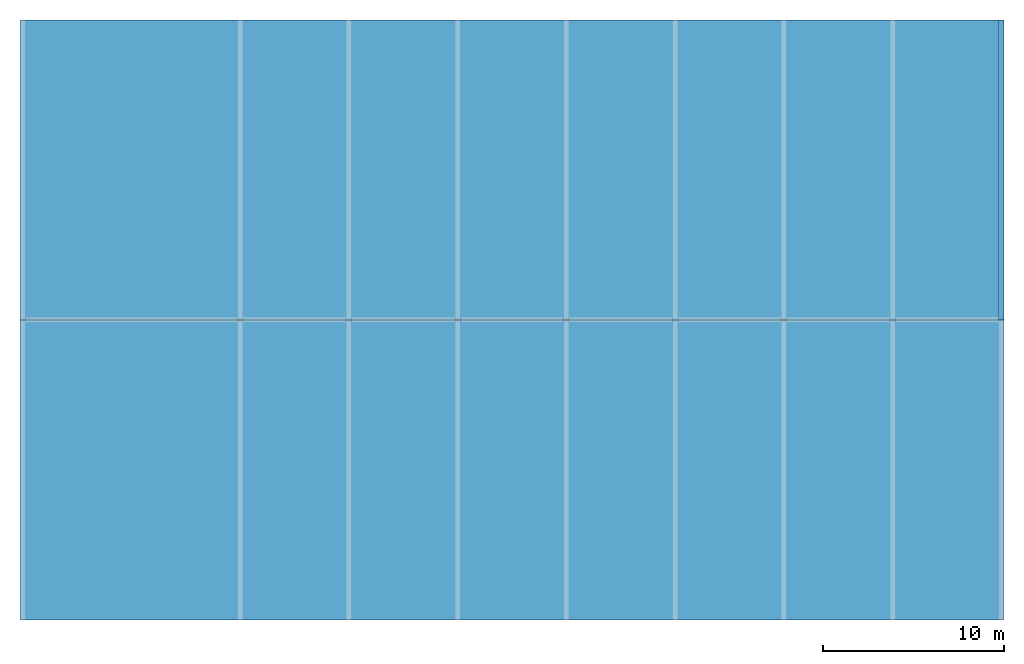
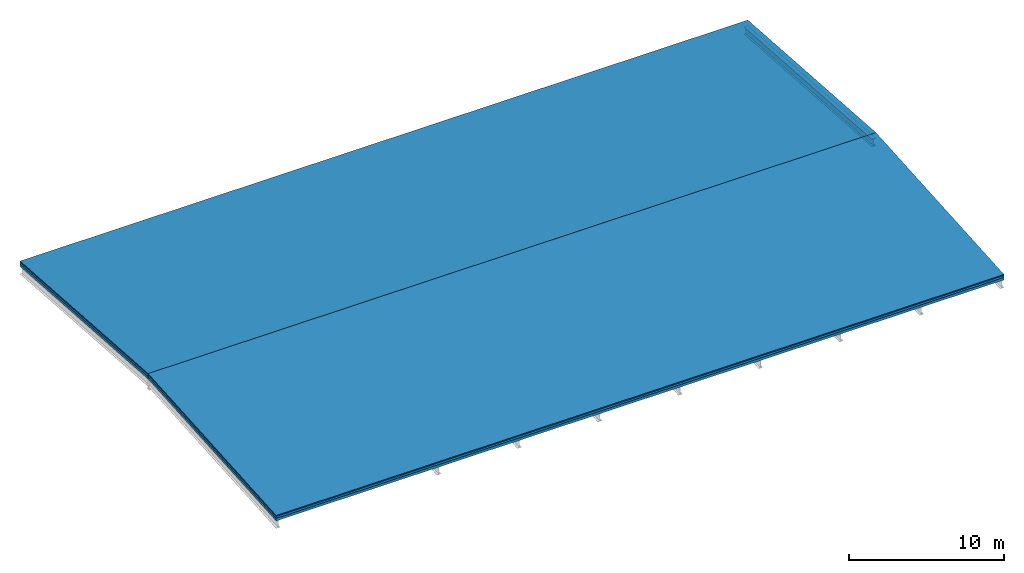
# One storey, part 3 of 3: 6 building element parts, 1 beam, 3 elements without a shape of their own.
"""IFC2X3 building model written with IfcOpenShell, lengths in millimetres."""

from ifc_helpers import new_model, entity, si_unit, converted_unit, frame, origin, origin_with_axes, place, context, subcontext, project, spatial, faceted_brep, material, element, aggregate, save


model = new_model("IFC2X3")

# Units and contexts
model_context = context("Model", 3, precision=1e-05, world=origin())
body_context = subcontext(model_context, "Body", "Model", "MODEL_VIEW")
ifc_project = project(units=[si_unit("LENGTHUNIT", "METRE", prefix="MILLI"), converted_unit("PLANEANGLEUNIT", "DEGREE", entity("IfcPlaneAngleMeasure", 0.0174532925199433), si_unit("PLANEANGLEUNIT", "RADIAN"), dimensions=[0, 0, 0, 0, 0, 0, 0]), si_unit("AREAUNIT", "SQUARE_METRE"), si_unit("VOLUMEUNIT", "CUBIC_METRE")], contexts=[model_context])

# Building, storey
building_placement = place(None, origin())
building = spatial("IfcBuilding", under=ifc_project, at=building_placement, CompositionType="ELEMENT")
storey_placement = place(building_placement, frame((0.0, 0.0, 7000.0), z_axis=(0.0, 0.0, 1.0), x_axis=(1.0, 0.0, 0.0)))
storey = spatial("IfcBuildingStorey", under=building, at=storey_placement, Name="Dach", CompositionType="ELEMENT", Elevation=7000.0)

# Beam
ifc_material_1 = material(Name="Stahl")
beam_placement = place(storey_placement, frame((53980.0, 33250.0, -17.48170298587866), z_axis=(0.0, 0.0, 1.0), x_axis=(-5.27561881390943e-15, -1.0, 0.0)))
element("IfcBeam", 1, at=beam_placement, inside=storey, material=ifc_material_1, context=body_context, shape_type="Brep", body=[
    faceted_brep([(16550.00000000001, 0.0, 1757.288737665103), (16550.00000000001, 0.0, 1727.288737665102), (0.0, 0.0, 570.0), (0.0, 0.0, 600.0), (16550.00000000001, 0.0, 1187.288737665102), (16550.00000000001, 0.0, 1157.288737665102), (0.0, 0.0, 0.0), (0.0, -7.275957614183426e-12, 30.0), (16550.00000000001, 300.0, 1757.288737665103), (16550.00000000001, 300.0, 1727.288737665102), (16550.00000000001, 157.75, 1727.288737665102), (16550.00000000001, 157.75, 1187.288737665102), (16550.00000000001, 300.0, 1187.288737665102), (16550.00000000001, 300.0, 1157.288737665102), (16550.00000000001, 0.0, 1157.288737665102), (16550.00000000001, 0.0, 1187.288737665102), (16550.00000000001, 142.25, 1187.288737665102), (16550.00000000001, 142.25, 1727.288737665102), (16550.00000000001, 0.0, 1727.288737665102), (16550.00000000001, 0.0, 1757.288737665103), (0.0, 300.0, 30.0), (0.0, 300.0, 0.0), (16550.00000000001, 300.0, 1157.288737665102), (16550.00000000001, 300.0, 1187.288737665102), (0.0, 300.0, 600.0), (0.0, 300.0, 570.0), (16550.00000000001, 300.0, 1727.288737665102), (16550.00000000001, 300.0, 1757.288737665103), (0.0, 0.0, 600.0), (0.0, 0.0, 570.0), (0.0, 142.25, 570.0), (0.0, 142.25, 30.0), (0.0, -7.275957614183426e-12, 30.0), (0.0, 0.0, 0.0), (0.0, 300.0, 0.0), (0.0, 300.0, 30.0), (0.0, 157.75, 30.0), (0.0, 157.75, 570.0), (0.0, 300.0, 570.0), (0.0, 300.0, 600.0), (16550.00000000001, 300.0, 1757.288737665103), (16550.00000000001, 0.0, 1757.288737665103), (0.0, 0.0, 600.0), (0.0, 300.0, 600.0), (16550.00000000001, 0.0, 1727.288737665102), (16550.00000000001, 142.25, 1727.288737665102), (0.0, 142.25, 570.0), (0.0, 0.0, 570.0), (16550.00000000001, 142.25, 1727.288737665102), (16550.00000000001, 142.25, 1187.288737665102), (0.0, 142.25, 30.0), (0.0, 142.25, 570.0), (16550.00000000001, 142.25, 1187.288737665102), (16550.00000000001, 0.0, 1187.288737665102), (0.0, -7.275957614183426e-12, 30.0), (0.0, 142.25, 30.0), (16550.00000000001, 0.0, 1157.288737665102), (16550.00000000001, 300.0, 1157.288737665102), (0.0, 300.0, 0.0), (0.0, 0.0, 0.0), (16550.00000000001, 300.0, 1187.288737665102), (16550.00000000001, 157.75, 1187.288737665102), (0.0, 157.75, 30.0), (0.0, 300.0, 30.0), (16550.00000000001, 157.75, 1187.288737665102), (16550.00000000001, 157.75, 1727.288737665102), (0.0, 157.75, 570.0), (0.0, 157.75, 30.0), (16550.00000000001, 157.75, 1727.288737665102), (16550.00000000001, 300.0, 1727.288737665102), (0.0, 300.0, 570.0), (0.0, 157.75, 570.0)], [[[0, 1, 2, 3]], [[4, 5, 6, 7]], [[8, 9, 10, 11, 12, 13, 14, 15, 16, 17, 18, 19]], [[20, 21, 22, 23]], [[24, 25, 26, 27]], [[28, 29, 30, 31, 32, 33, 34, 35, 36, 37, 38, 39]], [[40, 41, 42, 43]], [[44, 45, 46, 47]], [[48, 49, 50, 51]], [[52, 53, 54, 55]], [[56, 57, 58, 59]], [[60, 61, 62, 63]], [[64, 65, 66, 67]], [[68, 69, 70, 71]]], orient=[[False], [False], [False], [False], [False], [False], [False], [False], [False], [False], [False], [False], [False], [False]]),
])

# Roof, slabs, building element parts
roof_placement = place(storey_placement, frame((0.0, 0.0, -7000.0), z_axis=(0.0, 0.0, 1.0), x_axis=(1.0, 0.0, 0.0)))
roof = element("IfcRoof", 2, at=roof_placement, inside=storey, ShapeType="NOTDEFINED")
slab_1_placement = place(roof_placement, origin_with_axes())
slab_1 = element("IfcSlab", 3, at=slab_1_placement, PredefinedType="ROOF")
ifc_material_2 = material()
building_element_part_1_placement = place(slab_1_placement, origin_with_axes())
building_element_part_1 = element("IfcBuildingElementPart", 4, at=building_element_part_1_placement, material=ifc_material_2, context=body_context, shape_type="Brep", body=[
    faceted_brep([(-20.0, 33250.0, 7933.372961342529), (-20.0, 16700.0, 9090.661699007633), (54280.00000000012, 16700.0, 9090.661699007633), (54280.00000000012, 33250.0, 7933.372961342529), (-20.0, 33250.0, 8013.568313189024), (54280.00000000012, 33250.0, 8013.568313189024), (54280.00000000012, 16700.0, 9170.857050854127), (-20.0, 16700.0, 9170.857050854127), (-20.0, 16700.0, 9170.857050854127), (54280.00000000012, 16700.0, 9170.857050854127), (54280.00000000012, 16700.0, 9090.661699007633), (-20.0, 16700.0, 9090.661699007633), (54280.00000000012, 16700.0, 9170.857050854127), (54280.00000000012, 33250.0, 8013.568313189024), (54280.00000000012, 33250.0, 7933.372961342529), (54280.00000000012, 16700.0, 9090.661699007633), (54280.00000000012, 33250.0, 8013.568313189024), (-20.0, 33250.0, 8013.568313189024), (-20.0, 33250.0, 7933.372961342529), (54280.00000000012, 33250.0, 7933.372961342529), (-20.0, 33250.0, 8013.568313189024), (-20.0, 16700.0, 9170.857050854127), (-20.0, 16700.0, 9090.661699007633), (-20.0, 33250.0, 7933.372961342529)], [[[0, 1, 2, 3]], [[4, 5, 6, 7]], [[8, 9, 10, 11]], [[12, 13, 14, 15]], [[16, 17, 18, 19]], [[20, 21, 22, 23]]], orient=[[False], [False], [False], [False], [False], [False]]),
])
ifc_material_3 = material()
building_element_part_2_placement = place(slab_1_placement, origin_with_axes())
building_element_part_2 = element("IfcBuildingElementPart", 5, at=building_element_part_2_placement, material=ifc_material_3, context=body_context, shape_type="Brep", body=[
    faceted_brep([(-20.0, 33250.0, 7783.006676630353), (-20.0, 16700.0, 8940.295414295455), (54280.00000000012, 16700.0, 8940.295414295455), (54280.00000000012, 33250.0, 7783.006676630353), (-20.0, 33250.0, 7933.372961342529), (54280.00000000012, 33250.0, 7933.372961342529), (54280.00000000012, 16700.0, 9090.661699007633), (-20.0, 16700.0, 9090.661699007633), (-20.0, 16700.0, 9090.661699007633), (54280.00000000012, 16700.0, 9090.661699007633), (54280.00000000012, 16700.0, 8940.295414295455), (-20.0, 16700.0, 8940.295414295455), (54280.00000000012, 16700.0, 9090.661699007633), (54280.00000000012, 33250.0, 7933.372961342529), (54280.00000000012, 33250.0, 7783.006676630353), (54280.00000000012, 16700.0, 8940.295414295455), (54280.00000000012, 33250.0, 7933.372961342529), (-20.0, 33250.0, 7933.372961342529), (-20.0, 33250.0, 7783.006676630353), (54280.00000000012, 33250.0, 7783.006676630353), (-20.0, 33250.0, 7933.372961342529), (-20.0, 16700.0, 9090.661699007633), (-20.0, 16700.0, 8940.295414295455), (-20.0, 33250.0, 7783.006676630353)], [[[0, 1, 2, 3]], [[4, 5, 6, 7]], [[8, 9, 10, 11]], [[12, 13, 14, 15]], [[16, 17, 18, 19]], [[20, 21, 22, 23]]], orient=[[False], [False], [False], [False], [False], [False]]),
])
ifc_material_4 = material(Name="Trapezblech")
building_element_part_3_placement = place(slab_1_placement, origin_with_axes())
building_element_part_3 = element("IfcBuildingElementPart", 6, at=building_element_part_3_placement, material=ifc_material_4, context=body_context, shape_type="Brep", body=[
    faceted_brep([(-20.0, 33250.0, 7582.518297014119), (-20.0, 16700.00000000001, 8739.80703467922), (54280.00000000012, 16700.00000000001, 8739.80703467922), (54280.00000000012, 33250.0, 7582.518297014119), (-20.0, 33250.0, 7783.006676630353), (54280.00000000012, 33250.0, 7783.006676630353), (54280.00000000012, 16700.0, 8940.295414295455), (-20.0, 16700.0, 8940.295414295455), (-20.0, 16700.0, 8940.295414295455), (54280.00000000012, 16700.0, 8940.295414295455), (54280.00000000012, 16700.00000000001, 8739.80703467922), (-20.0, 16700.00000000001, 8739.80703467922), (54280.00000000012, 16700.0, 8940.295414295455), (54280.00000000012, 33250.0, 7783.006676630353), (54280.00000000012, 33250.0, 7582.518297014119), (54280.00000000012, 16700.00000000001, 8739.80703467922), (54280.00000000012, 33250.0, 7783.006676630353), (-20.0, 33250.0, 7783.006676630353), (-20.0, 33250.0, 7582.518297014119), (54280.00000000012, 33250.0, 7582.518297014119), (-20.0, 33250.0, 7783.006676630353), (-20.0, 16700.0, 8940.295414295455), (-20.0, 16700.00000000001, 8739.80703467922), (-20.0, 33250.0, 7582.518297014119)], [[[0, 1, 2, 3]], [[4, 5, 6, 7]], [[8, 9, 10, 11]], [[12, 13, 14, 15]], [[16, 17, 18, 19]], [[20, 21, 22, 23]]], orient=[[False], [False], [False], [False], [False], [False]]),
])
aggregate(slab_1, [building_element_part_1, building_element_part_2, building_element_part_3])
slab_2_placement = place(roof_placement, origin_with_axes())
slab_2 = element("IfcSlab", 7, at=slab_2_placement, PredefinedType="ROOF")
aggregate(roof, [slab_1, slab_2])
ifc_material_5 = material()
building_element_part_4_placement = place(slab_2_placement, origin_with_axes())
building_element_part_4 = element("IfcBuildingElementPart", 8, at=building_element_part_4_placement, material=ifc_material_5, context=body_context, shape_type="Brep", body=[
    faceted_brep([(-20.0, 16700.0, 9090.661699007633), (-20.0, 149.9999999999964, 7933.372961342529), (54280.00000000012, 150.0, 7933.372961342529), (54280.00000000012, 16700.0, 9090.661699007633), (-20.0, 16700.0, 9170.857050854127), (54280.00000000012, 16700.0, 9170.857050854127), (54280.00000000012, 149.9999999999999, 8013.568313189024), (-20.0, 149.9999999999963, 8013.568313189023), (-20.0, 149.9999999999963, 8013.568313189023), (54280.00000000012, 149.9999999999999, 8013.568313189024), (54280.00000000012, 150.0, 7933.372961342529), (-20.0, 149.9999999999964, 7933.372961342529), (54280.00000000012, 149.9999999999999, 8013.568313189024), (54280.00000000012, 16700.0, 9170.857050854127), (54280.00000000012, 16700.0, 9090.661699007633), (54280.00000000012, 150.0, 7933.372961342529), (54280.00000000012, 16700.0, 9170.857050854127), (-20.0, 16700.0, 9170.857050854127), (-20.0, 16700.0, 9090.661699007633), (54280.00000000012, 16700.0, 9090.661699007633), (-20.0, 16700.0, 9170.857050854127), (-20.0, 149.9999999999963, 8013.568313189023), (-20.0, 149.9999999999964, 7933.372961342529), (-20.0, 16700.0, 9090.661699007633)], [[[0, 1, 2, 3]], [[4, 5, 6, 7]], [[8, 9, 10, 11]], [[12, 13, 14, 15]], [[16, 17, 18, 19]], [[20, 21, 22, 23]]], orient=[[False], [False], [False], [False], [False], [False]]),
])
ifc_material_6 = material()
building_element_part_5_placement = place(slab_2_placement, origin_with_axes())
building_element_part_5 = element("IfcBuildingElementPart", 9, at=building_element_part_5_placement, material=ifc_material_6, context=body_context, shape_type="Brep", body=[
    faceted_brep([(-20.0, 16700.0, 8940.295414295455), (-20.0, 149.9999999999964, 7783.006676630352), (54280.00000000012, 150.0, 7783.006676630353), (54280.00000000012, 16700.0, 8940.295414295455), (-20.0, 16700.0, 9090.661699007633), (54280.00000000012, 16700.0, 9090.661699007633), (54280.00000000012, 150.0, 7933.372961342529), (-20.0, 149.9999999999964, 7933.372961342529), (-20.0, 149.9999999999964, 7933.372961342529), (54280.00000000012, 150.0, 7933.372961342529), (54280.00000000012, 150.0, 7783.006676630353), (-20.0, 149.9999999999964, 7783.006676630352), (54280.00000000012, 150.0, 7933.372961342529), (54280.00000000012, 16700.0, 9090.661699007633), (54280.00000000012, 16700.0, 8940.295414295455), (54280.00000000012, 150.0, 7783.006676630353), (54280.00000000012, 16700.0, 9090.661699007633), (-20.0, 16700.0, 9090.661699007633), (-20.0, 16700.0, 8940.295414295455), (54280.00000000012, 16700.0, 8940.295414295455), (-20.0, 16700.0, 9090.661699007633), (-20.0, 149.9999999999964, 7933.372961342529), (-20.0, 149.9999999999964, 7783.006676630352), (-20.0, 16700.0, 8940.295414295455)], [[[0, 1, 2, 3]], [[4, 5, 6, 7]], [[8, 9, 10, 11]], [[12, 13, 14, 15]], [[16, 17, 18, 19]], [[20, 21, 22, 23]]], orient=[[False], [False], [False], [False], [False], [False]]),
])
ifc_material_7 = material(Name="Trapezblech")
building_element_part_6_placement = place(slab_2_placement, origin_with_axes())
building_element_part_6 = element("IfcBuildingElementPart", 10, at=building_element_part_6_placement, material=ifc_material_7, context=body_context, shape_type="Brep", body=[
    faceted_brep([(-20.0, 16700.00000000001, 8739.80703467922), (-20.0, 149.9999999999964, 7582.518297014116), (54280.00000000012, 150.0, 7582.518297014117), (54280.00000000012, 16700.00000000001, 8739.80703467922), (-20.0, 16700.0, 8940.295414295455), (54280.00000000012, 16700.0, 8940.295414295455), (54280.00000000012, 150.0, 7783.006676630353), (-20.0, 149.9999999999964, 7783.006676630352), (-20.0, 149.9999999999964, 7783.006676630352), (54280.00000000012, 150.0, 7783.006676630353), (54280.00000000012, 150.0, 7582.518297014117), (-20.0, 149.9999999999964, 7582.518297014116), (54280.00000000012, 150.0, 7783.006676630353), (54280.00000000012, 16700.0, 8940.295414295455), (54280.00000000012, 16700.00000000001, 8739.80703467922), (54280.00000000012, 150.0, 7582.518297014117), (54280.00000000012, 16700.0, 8940.295414295455), (-20.0, 16700.0, 8940.295414295455), (-20.0, 16700.00000000001, 8739.80703467922), (54280.00000000012, 16700.00000000001, 8739.80703467922), (-20.0, 16700.0, 8940.295414295455), (-20.0, 149.9999999999964, 7783.006676630352), (-20.0, 149.9999999999964, 7582.518297014116), (-20.0, 16700.00000000001, 8739.80703467922)], [[[0, 1, 2, 3]], [[4, 5, 6, 7]], [[8, 9, 10, 11]], [[12, 13, 14, 15]], [[16, 17, 18, 19]], [[20, 21, 22, 23]]], orient=[[False], [False], [False], [False], [False], [False]]),
])
aggregate(slab_2, [building_element_part_4, building_element_part_5, building_element_part_6])

save(model, "model.ifc")
